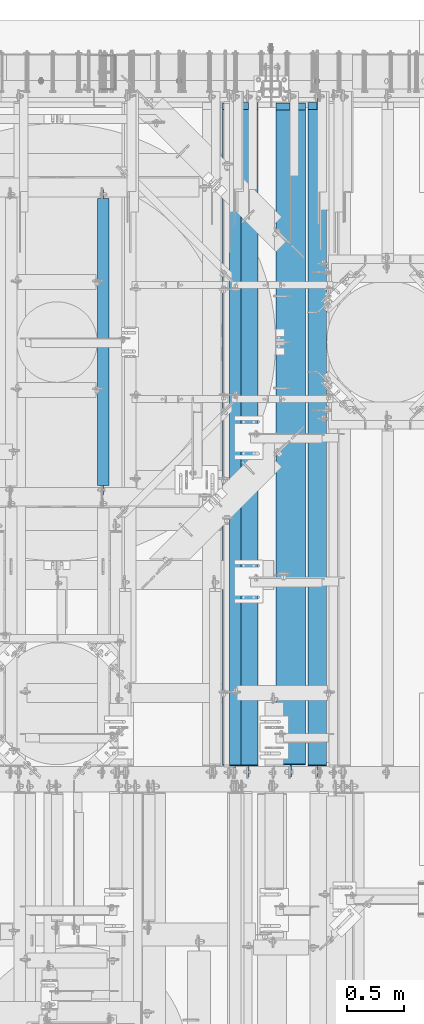
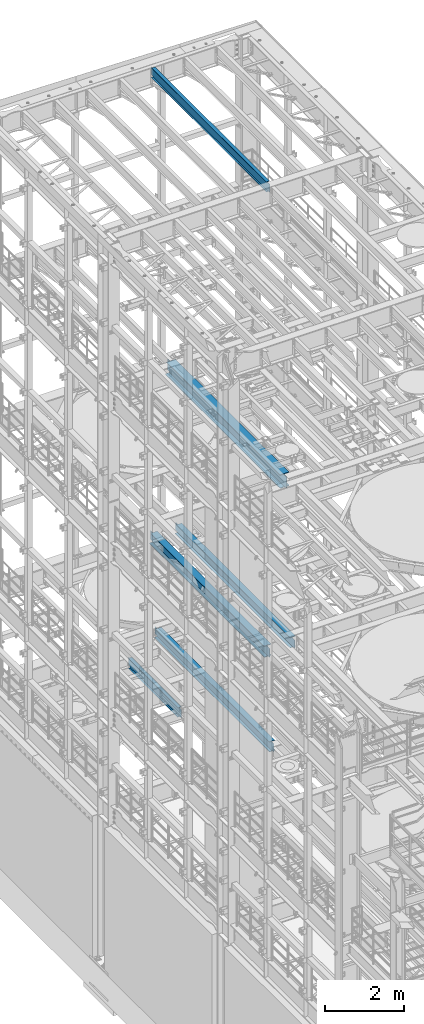
# One storey, part 1061 of 1876: 6 beams, 6 elements without a shape of their own.
"""IFC2X3 building model written with IfcOpenShell, lengths in millimetres."""

from ifc_helpers import new_model, si_unit, frame, origin_with_axes, place, context, subcontext, project, spatial, faceted_brep, material, type_object, element, aggregate, save


model = new_model("IFC2X3")

# Units and contexts
model_context = context("Model", 3, precision=1e-05, world=origin_with_axes())
body_context = subcontext(model_context, "Body", "Model", "MODEL_VIEW")
ifc_project = project(units=[si_unit("LENGTHUNIT", "METRE", prefix="MILLI"), si_unit("AREAUNIT", "SQUARE_METRE"), si_unit("VOLUMEUNIT", "CUBIC_METRE"), si_unit("MASSUNIT", "GRAM", prefix="KILO"), si_unit("TIMEUNIT", "SECOND"), si_unit("PLANEANGLEUNIT", "RADIAN"), si_unit("SOLIDANGLEUNIT", "STERADIAN"), si_unit("THERMODYNAMICTEMPERATUREUNIT", "DEGREE_CELSIUS"), si_unit("LUMINOUSINTENSITYUNIT", "LUMEN")], contexts=[model_context])

# Site, building, storey
site_placement = place(None, origin_with_axes())
site = spatial("IfcSite", under=ifc_project, at=site_placement, CompositionType="ELEMENT")
building_placement = place(site_placement, origin_with_axes())
building = spatial("IfcBuilding", under=site, at=building_placement, Name="Undefined", CompositionType="ELEMENT")
storey_placement = place(building_placement, origin_with_axes())
storey = spatial("IfcBuildingStorey", under=building, at=storey_placement, Name="Undefined", CompositionType="ELEMENT", Elevation=0.0)

# Assembly, beam
assembly_1_placement = place(storey_placement, origin_with_axes())
assembly_1 = element("IfcElementAssembly", 1, at=assembly_1_placement, inside=storey, Name="BEAM", AssemblyPlace="NOTDEFINED", PredefinedType="RIGID_FRAME")
ifc_material = material(Name="STEEL/A992")
beam_type_1 = type_object("IfcBeamType", Name="W12X26", PredefinedType="NOTDEFINED")
beam_1_placement = place(assembly_1_placement, frame((4879.975, 7620.0, 4975.225), z_axis=(0.0, 0.0, 1.0), x_axis=(0.0, 1.0, 0.0)))
beam_1 = element("IfcBeam", 2, at=beam_1_placement, type_object=beam_type_1, material=ifc_material, Name="BEAM", ObjectType="W12X26", context=body_context, shape_type="Brep", body=[
    faceted_brep([(19.8437512414296, -3.17500000000109, -130.175), (19.8437487585795, 3.17499999999927, -130.175), (102.393750190735, 3.17500000000018, -130.174999999999), (102.393750190735, -3.17500000000018, -130.174999999999), (107.25382970878, 3.17500000000018, -131.141729922587), (107.25382970878, -3.17500000000018, -131.141729922587), (111.374006176934, 3.17500000000018, -133.894743823064), (111.374006176934, -3.17500000000018, -133.894743823064), (114.127020077412, 3.17500000000018, -138.014920291218), (114.127020077412, -3.17500000000018, -138.014920291218), (115.09375, -3.17500000000018, -142.874999809264), (115.09375, 3.17500000000018, -142.874999809264), (115.09375, 3.17500000000018, -146.05), (115.09375, 82.5500000000002, -146.05), (115.09375, 82.5500000000002, -155.575000000001), (115.09375, -82.5500000000002, -155.575000000001), (115.09375, -82.5500000000002, -146.05), (115.09375, -3.17500000000018, -146.05), (5914.23125, 82.5500000000002, 146.05), (5914.23125, 3.17500000000018, 146.05), (127.79375, 3.17500000000018, 146.05), (127.793782276814, 82.5500000000102, 146.05), (115.09378246755, -3.17499999999654, 117.474999999999), (115.093782467549, 3.17500000000382, 117.474999999999), (19.8437487585795, 3.17499999999927, 117.474999999999), (19.8437512414296, -3.17500000000109, 117.474999999999), (119.953861985596, -3.17499999999654, 118.441729922587), (119.953861985596, 3.17500000000382, 118.441729922587), (124.074038453751, -3.17499999999654, 121.194743823065), (124.074038453751, 3.17500000000382, 121.194743823065), (126.82705235423, -3.17499999999654, 125.314920291219), (126.827052354229, 3.17500000000473, 125.314920291219), (127.793782276818, -3.17499999999654, 130.174999809265), (127.793782276817, 3.17500000000382, 130.174999809265), (5914.23125, -82.5500000000002, 155.575), (5914.23125, 82.5500000000002, 155.575), (127.793782276814, 82.5500000000102, 155.575), (127.793782276821, -82.5500000000029, 155.575), (5914.23125, -82.5500000000002, 146.05), (127.793782276821, -82.5500000000029, 146.05), (5914.23125, -3.17500000000018, 146.05), (127.79375, -3.17500000000018, 146.05), (5914.23125, -3.17500000000018, 117.474999809267), (5914.23125, 3.17500000000018, 117.474999809267), (5915.19797992259, -3.17500000000018, 112.614920291221), (5915.19797992259, 3.17500000000018, 112.614920291221), (5917.95099382307, -3.17500000000018, 108.494743823067), (5917.95099382307, 3.17500000000018, 108.494743823067), (5922.07117029122, -3.17500000000018, 105.741729922589), (5922.07117029122, 3.17500000000018, 105.741729922589), (5926.93124980926, -3.17500000000018, 104.775000000001), (5926.93124980926, 3.17500000000018, 104.775000000001), (6072.98125, -3.17500000000018, 104.775000000001), (6072.98125, 3.17500000000018, 104.775000000001), (6072.98125, -3.17500000000018, -130.174999999999), (6072.98125, 3.17500000000018, -130.174999999999), (5990.43124980926, -3.17500000000018, -130.174999999999), (5990.43124980926, 3.17500000000018, -130.174999999999), (5985.57117029122, -3.17500000000018, -131.141729922587), (5985.57117029122, 3.17500000000018, -131.141729922587), (5981.45099382307, -3.17500000000018, -133.894743823065), (5981.45099382307, 3.17500000000018, -133.894743823065), (5978.69797992259, -3.17500000000018, -138.014920291219), (5978.69797992259, 3.17500000000018, -138.014920291219), (5977.73125, -3.17500000000018, -142.874999809264), (5977.73125, 3.17500000000018, -142.874999809264), (5977.73125, -3.17500000000018, -146.05), (5977.73125, -82.5500000000002, -146.05), (5977.73125, -82.5500000000002, -155.575), (5977.73125, 82.5500000000002, -155.575), (5977.73125, 82.5500000000002, -146.05), (5977.73125, 3.17500000000018, -146.05)], [[[0, 1, 2, 3]], [[3, 2, 4, 5]], [[5, 4, 6, 7]], [[7, 6, 8, 9]], [[10, 11, 12, 13, 14, 15, 16, 17]], [[9, 8, 11, 10]], [[18, 19, 20, 21]], [[22, 23, 24, 25]], [[26, 27, 23, 22]], [[28, 29, 27, 26]], [[30, 31, 29, 28]], [[32, 33, 31, 30]], [[34, 35, 36, 37]], [[38, 34, 37, 39]], [[40, 38, 39, 41]], [[37, 36, 21, 20, 33, 32, 41, 39]], [[35, 18, 21, 36]], [[34, 38, 40, 42, 43, 19, 18, 35]], [[44, 45, 43, 42]], [[46, 47, 45, 44]], [[48, 49, 47, 46]], [[50, 51, 49, 48]], [[52, 53, 51, 50]], [[53, 52, 54, 55]], [[54, 56, 57, 55]], [[58, 59, 57, 56]], [[60, 61, 59, 58]], [[62, 63, 61, 60]], [[64, 65, 63, 62]], [[66, 67, 68, 69, 70, 71, 65, 64]], [[67, 66, 17, 16]], [[68, 67, 16, 15]], [[69, 68, 15, 14]], [[70, 69, 14, 13]], [[71, 70, 13, 12]], [[6, 4, 2, 1, 24, 23, 27, 29, 31, 33, 20, 19, 43, 45, 47, 49, 51, 53, 55, 57, 59, 61, 63, 65, 71, 12, 11, 8]], [[25, 24, 1, 0]], [[66, 64, 62, 60, 58, 56, 54, 52, 50, 48, 46, 44, 42, 40, 41, 32, 30, 28, 26, 22, 25, 0, 3, 5, 7, 9, 10, 17]]]),
])
aggregate(assembly_1, [beam_1])

assembly_2_placement = place(storey_placement, origin_with_axes())
assembly_2 = element("IfcElementAssembly", 3, at=assembly_2_placement, inside=storey, Name="BEAM", AssemblyPlace="NOTDEFINED", PredefinedType="RIGID_FRAME")
beam_type_2 = type_object("IfcBeamType", Name="W12X16", PredefinedType="NOTDEFINED")
beam_2_placement = place(assembly_2_placement, frame((3594.1, 10115.55, 4978.4), z_axis=(0.0, 0.0, 1.0), x_axis=(0.0, 1.0, 0.0)))
beam_2 = element("IfcBeam", 4, at=beam_2_placement, type_object=beam_type_2, material=ifc_material, Name="BEAM", ObjectType="W12X16", context=body_context, shape_type="Brep", body=[
    faceted_brep([(15.8749999999982, -3.17500000000018, -127.0), (15.8749999999982, 3.17500000000018, -127.0), (98.425000190733, 3.17500000000018, -127.0), (98.425000190733, -3.17500000000018, -127.0), (103.285079708779, 3.17500000000018, -127.966729922588), (103.285079708779, -3.17500000000018, -127.966729922588), (107.405256176932, 3.17500000000018, -130.719743823065), (107.405256176932, -3.17500000000018, -130.719743823065), (110.158270077411, 3.17500000000018, -134.839920291219), (110.158270077411, -3.17500000000018, -134.839920291219), (111.124999999998, -3.17500000000018, -139.699999809265), (111.124999999998, 3.17500000000018, -139.699999809265), (111.124999999998, 3.17500000000018, -146.049999999999), (111.124999999998, 50.8000000000002, -146.049999999999), (111.124999999998, 50.8000000000002, -152.400000000001), (111.124999999998, -50.8000000000002, -152.400000000001), (111.124999999998, -50.8000000000002, -146.049999999999), (111.124999999998, -3.17500000000018, -146.049999999999), (2632.07499999958, 50.8000000000002, 146.05), (2632.07499999958, 3.17500000000018, 146.05), (98.4250000000029, 3.17500000000018, 146.049999999999), (98.4250000000029, 50.8000000000002, 146.049999999999), (85.7250001907378, -3.17500000000018, 127.000000000001), (85.7250001907378, 3.17500000000018, 127.000000000001), (15.875, 3.17500000000018, 127.000000000001), (15.875, -3.17500000000018, 127.000000000001), (90.5850797087842, -3.17500000000018, 127.966729922588), (90.5850797087842, 3.17500000000018, 127.966729922588), (94.7052561769378, -3.17500000000018, 130.719743823067), (94.7052561769378, 3.17500000000018, 130.719743823067), (97.4582700774154, -3.17500000000018, 134.839920291221), (97.4582700774154, 3.17500000000018, 134.839920291221), (98.4250000000029, -3.17500000000018, 139.699999809266), (98.4250000000029, 3.17500000000018, 139.699999809266), (2632.07499999958, -50.8000000000002, 152.4), (2632.07499999958, 50.8000000000002, 152.4), (98.4250000000029, 50.8000000000002, 152.4), (98.4250000000029, -50.8000000000002, 152.4), (2632.07499999958, -50.8000000000002, 146.05), (98.4250000000029, -50.8000000000002, 146.049999999999), (2632.07499999958, -3.17500000000018, 146.05), (98.4250000000029, -3.17500000000018, 146.049999999999), (2632.07499999958, -3.17500000000018, 139.699999809266), (2632.07499999958, 3.17500000000018, 139.699999809266), (2633.04172992217, -3.17500000000018, 134.839920291221), (2633.04172992217, 3.17500000000018, 134.839920291221), (2635.79474382265, -3.17500000000018, 130.719743823067), (2635.79474382265, 3.17500000000018, 130.719743823067), (2639.9149202908, -3.17500000000018, 127.966729922588), (2639.9149202908, 3.17500000000018, 127.966729922588), (2644.77499980885, -3.17500000000018, 127.000000000001), (2644.77499980885, 3.17500000000018, 127.000000000001), (2714.62499999958, -3.17500000000018, 127.000000000001), (2714.62499999958, 3.17500000000018, 127.000000000001), (2714.62499999958, -3.17500000000018, -126.999999999999), (2714.62499999958, 3.17500000000018, -126.999999999999), (2632.07499980885, -3.17500000000018, -126.999999999999), (2632.07499980885, 3.17500000000018, -126.999999999999), (2627.2149202908, -3.17500000000018, -127.966729922587), (2627.2149202908, 3.17500000000018, -127.966729922587), (2623.09474382265, -3.17500000000018, -130.719743823065), (2623.09474382265, 3.17500000000018, -130.719743823065), (2620.34172992217, -3.17500000000018, -134.839920291219), (2620.34172992217, 3.17500000000018, -134.839920291219), (2619.37499999958, -3.17500000000018, -139.699999809264), (2619.37499999958, 3.17500000000018, -139.699999809264), (2619.37499999958, -3.17500000000018, -146.05), (2619.37499999958, -50.8000000000002, -146.05), (2619.37499999958, -50.8000000000002, -152.4), (2619.37499999958, 50.8000000000002, -152.4), (2619.37499999958, 50.8000000000002, -146.05), (2619.37499999958, 3.17500000000018, -146.05)], [[[0, 1, 2, 3]], [[3, 2, 4, 5]], [[5, 4, 6, 7]], [[7, 6, 8, 9]], [[10, 11, 12, 13, 14, 15, 16, 17]], [[9, 8, 11, 10]], [[18, 19, 20, 21]], [[22, 23, 24, 25]], [[26, 27, 23, 22]], [[28, 29, 27, 26]], [[30, 31, 29, 28]], [[32, 33, 31, 30]], [[34, 35, 36, 37]], [[38, 34, 37, 39]], [[40, 38, 39, 41]], [[37, 36, 21, 20, 33, 32, 41, 39]], [[35, 18, 21, 36]], [[34, 38, 40, 42, 43, 19, 18, 35]], [[44, 45, 43, 42]], [[46, 47, 45, 44]], [[48, 49, 47, 46]], [[50, 51, 49, 48]], [[52, 53, 51, 50]], [[53, 52, 54, 55]], [[54, 56, 57, 55]], [[58, 59, 57, 56]], [[60, 61, 59, 58]], [[62, 63, 61, 60]], [[64, 65, 63, 62]], [[66, 67, 68, 69, 70, 71, 65, 64]], [[67, 66, 17, 16]], [[68, 67, 16, 15]], [[69, 68, 15, 14]], [[70, 69, 14, 13]], [[71, 70, 13, 12]], [[6, 4, 2, 1, 24, 23, 27, 29, 31, 33, 20, 19, 43, 45, 47, 49, 51, 53, 55, 57, 59, 61, 63, 65, 71, 12, 11, 8]], [[25, 24, 1, 0]], [[66, 64, 62, 60, 58, 56, 54, 52, 50, 48, 46, 44, 42, 40, 41, 32, 30, 28, 26, 22, 25, 0, 3, 5, 7, 9, 10, 17]]]),
])
aggregate(assembly_2, [beam_2])

assembly_3_placement = place(storey_placement, origin_with_axes())
assembly_3 = element("IfcElementAssembly", 5, at=assembly_3_placement, inside=storey, Name="BEAM", AssemblyPlace="NOTDEFINED", PredefinedType="RIGID_FRAME")
beam_3_placement = place(assembly_3_placement, frame((4762.5, 7620.0, 22402.8), z_axis=(0.0, 0.0, 1.0), x_axis=(0.0, 1.0, 0.0)))
beam_3 = element("IfcBeam", 6, at=beam_3_placement, type_object=beam_type_2, material=ifc_material, Name="BEAM", ObjectType="W12X16", context=body_context, shape_type="Brep", body=[
    faceted_brep([(19.84375, -3.17499999999995, -126.999999999996), (19.84375, 3.17499999999995, -126.999999999996), (102.393750190735, 3.17500000000018, -127.000000000001), (102.393750190735, -3.17500000000018, -127.000000000001), (107.25382970878, 3.17500000000018, -127.966729922588), (107.25382970878, -3.17500000000018, -127.966729922588), (111.374006176934, 3.17500000000018, -130.719743823067), (111.374006176934, -3.17500000000018, -130.719743823067), (114.127020077412, 3.17500000000018, -134.839920291221), (114.127020077412, -3.17500000000018, -134.839920291221), (115.09375, -3.17500000000018, -139.699999809266), (115.09375, 3.17500000000018, -139.699999809266), (115.09375, 3.17500000000018, -146.05), (115.09375, 50.8000000000002, -146.05), (115.09375, 50.8000000000002, -152.4), (115.09375, -50.8000000000002, -152.4), (115.09375, -50.8000000000002, -146.05), (115.09375, -3.17500000000018, -146.05), (127.79375, 3.17500000000018, 146.05), (127.79375, 50.8000000000002, 146.05), (5968.20625, 50.8, 146.05), (5968.20625, 3.17499999999995, 146.05), (115.093750190735, -3.17500000000018, 114.299999999999), (115.093750190735, 3.17500000000018, 114.299999999999), (19.84375, 3.17500000000018, 114.299999999999), (19.84375, -3.17500000000018, 114.299999999999), (119.95382970878, -3.17500000000018, 115.266729922587), (119.95382970878, 3.17500000000018, 115.266729922587), (124.074006176934, -3.17500000000018, 118.019743823065), (124.074006176934, 3.17500000000018, 118.019743823065), (126.827020077412, -3.17500000000018, 122.139920291219), (126.827020077412, 3.17500000000018, 122.139920291219), (127.79375, -3.17500000000018, 126.999999809264), (127.79375, 3.17500000000018, 126.999999809264), (127.79375, 50.8000000000002, 152.4), (127.79375, -50.8000000000002, 152.4), (5968.20625, -50.8, 152.4), (5968.20625, 50.8, 152.4), (127.79375, -50.8000000000002, 146.05), (5968.20625, -50.8, 146.05), (127.79375, -3.17500000000018, 146.05), (5968.20625, -3.17499999999995, 146.05), (5968.20625, -3.17499999999995, 126.999999809264), (5968.20625, 3.17499999999995, 126.999999809264), (5969.17297992259, -3.17499999999995, 122.139920291219), (5969.17297992259, 3.17499999999995, 122.139920291219), (5971.92599382307, -3.17499999999995, 118.019743823065), (5971.92599382307, 3.17499999999995, 118.019743823065), (5976.04617029122, -3.17499999999995, 115.266729922587), (5976.04617029122, 3.17499999999995, 115.266729922587), (5980.90624980927, -3.17499999999995, 114.299999999999), (5980.90624980927, 3.17499999999995, 114.299999999999), (6076.15625, -3.17499999999995, 114.299999999999), (6076.15625, 3.17499999999995, 114.299999999999), (6076.15625, -3.17499999999995, -126.999999999996), (6076.15625, 3.17499999999995, -126.999999999996), (5993.60624980927, -3.17499999999995, -127.000000000001), (5993.60624980927, 3.17499999999995, -127.000000000001), (5988.74617029122, -3.17499999999995, -127.966729922588), (5988.74617029122, 3.17499999999995, -127.966729922588), (5984.62599382307, -3.17499999999995, -130.719743823067), (5984.62599382307, 3.17499999999995, -130.719743823067), (5981.87297992259, -3.17499999999995, -134.839920291221), (5981.87297992259, 3.17499999999995, -134.839920291221), (5980.90625, -3.17499999999995, -139.699999809266), (5980.90625, 3.17499999999995, -139.699999809266), (5980.90625, -3.17499999999995, -146.05), (5980.90625, -50.8, -146.05), (5980.90625, -50.8, -152.4), (5980.90625, 50.8, -152.4), (5980.90625, 50.8, -146.05), (5980.90625, 3.17499999999995, -146.05)], [[[0, 1, 2, 3]], [[3, 2, 4, 5]], [[5, 4, 6, 7]], [[7, 6, 8, 9]], [[10, 11, 12, 13, 14, 15, 16, 17]], [[9, 8, 11, 10]], [[18, 19, 20, 21]], [[22, 23, 24, 25]], [[26, 27, 23, 22]], [[28, 29, 27, 26]], [[30, 31, 29, 28]], [[32, 33, 31, 30]], [[34, 35, 36, 37]], [[35, 38, 39, 36]], [[38, 40, 41, 39]], [[35, 34, 19, 18, 33, 32, 40, 38]], [[19, 34, 37, 20]], [[36, 39, 41, 42, 43, 21, 20, 37]], [[44, 45, 43, 42]], [[46, 47, 45, 44]], [[48, 49, 47, 46]], [[50, 51, 49, 48]], [[52, 53, 51, 50]], [[53, 52, 54, 55]], [[54, 56, 57, 55]], [[58, 59, 57, 56]], [[60, 61, 59, 58]], [[62, 63, 61, 60]], [[64, 65, 63, 62]], [[66, 67, 68, 69, 70, 71, 65, 64]], [[17, 16, 67, 66]], [[16, 15, 68, 67]], [[15, 14, 69, 68]], [[14, 13, 70, 69]], [[13, 12, 71, 70]], [[59, 61, 63, 65, 71, 12, 11, 8, 6, 4, 2, 1, 24, 23, 27, 29, 31, 33, 18, 21, 43, 45, 47, 49, 51, 53, 55, 57]], [[25, 24, 1, 0]], [[52, 50, 48, 46, 44, 42, 41, 40, 32, 30, 28, 26, 22, 25, 0, 3, 5, 7, 9, 10, 17, 66, 64, 62, 60, 58, 56, 54]]]),
])
aggregate(assembly_3, [beam_3])

assembly_4_placement = place(storey_placement, origin_with_axes())
assembly_4 = element("IfcElementAssembly", 7, at=assembly_4_placement, inside=storey, Name="BEAM", AssemblyPlace="NOTDEFINED", PredefinedType="RIGID_FRAME")
beam_type_3 = type_object("IfcBeamType", Name="W12X30", PredefinedType="NOTDEFINED")
beam_4_placement = place(assembly_4_placement, frame((5486.4, 7620.0, 7996.2375), z_axis=(0.0, 0.0, 1.0), x_axis=(0.0, 1.0, 0.0)))
beam_4 = element("IfcBeam", 8, at=beam_4_placement, type_object=beam_type_3, material=ifc_material, Name="BEAM", ObjectType="W12X30", context=body_context, shape_type="Brep", body=[
    faceted_brep([(19.8437500000002, -3.17500000000018, -131.762499999993), (19.8437500000002, 3.17500000000018, -131.762499999993), (102.393750190735, 3.17500000000018, -131.762500000001), (102.393750190735, -3.17500000000018, -131.762500000001), (107.25382970878, 3.17500000000018, -132.729229922588), (107.25382970878, -3.17500000000018, -132.729229922588), (111.374006176934, 3.17500000000018, -135.482243823067), (111.374006176934, -3.17500000000018, -135.482243823067), (114.127020077412, 3.17500000000018, -139.60242029122), (114.127020077412, -3.17500000000018, -139.60242029122), (115.09375, -3.17500000000018, -144.462499809266), (115.09375, 3.17500000000018, -144.462499809266), (115.09375, 3.17500000000018, -146.05), (115.09375, 82.5500000000002, -146.05), (115.09375, 82.5500000000002, -157.1625), (115.09375, -82.5500000000002, -157.1625), (115.09375, -82.5500000000002, -146.05), (115.09375, -3.17500000000018, -146.05), (5914.23125, 82.5500000000002, 146.05), (5914.23125, 3.17500000000018, 146.05), (127.79375, 3.17500000000018, 146.05), (127.793782276814, 82.5500000000102, 146.05), (115.09374930124, -3.17499999999995, 119.062500000004), (115.09374930124, 3.17499999999995, 119.062500000004), (19.8437491105051, 3.17499999999995, 119.062500000004), (19.8437491105051, -3.17499999999995, 119.062500000004), (119.953828819285, -3.17499999999995, 120.029229922591), (119.953828819285, 3.17499999999995, 120.029229922591), (124.074005287439, -3.17499999999995, 122.782243823069), (124.074005287439, 3.17499999999995, 122.782243823069), (126.827019187917, -3.17499999999995, 126.902420291222), (126.827019187917, 3.17499999999995, 126.902420291222), (127.793749110505, -3.17499999999995, 131.762499809269), (127.793749110505, 3.17499999999995, 131.762499809269), (5914.23125, -82.5500000000002, 157.1625), (5914.23125, 82.5500000000002, 157.1625), (127.793749110505, 82.55, 157.162499999999), (127.793749110505, -82.55, 157.162499999999), (5914.23125, -82.5500000000002, 146.05), (127.793782276821, -82.5500000000029, 146.05), (5914.23125, -3.17500000000018, 146.05), (127.79375, -3.17500000000018, 146.05), (5914.23125, -3.17500000000018, 119.062499809265), (5914.23125, 3.17500000000018, 119.062499809265), (5915.19797992259, -3.17500000000018, 114.20242029122), (5915.19797992259, 3.17500000000018, 114.20242029122), (5917.95099382307, -3.17500000000018, 110.082243823066), (5917.95099382307, 3.17500000000018, 110.082243823066), (5922.07117029122, -3.17500000000018, 107.329229922588), (5922.07117029122, 3.17500000000018, 107.329229922588), (5926.93124980926, -3.17500000000018, 106.3625), (5926.93124980926, 3.17500000000018, 106.3625), (6072.98125, -3.17500000000018, 106.3625), (6072.98125, 3.17500000000018, 106.3625), (6072.98125, -3.17500000000018, -131.7625), (6072.98125, 3.17500000000018, -131.7625), (5990.43124980926, -3.17500000000018, -131.7625), (5990.43124980926, 3.17500000000018, -131.7625), (5985.57117029122, -3.17500000000018, -132.729229922587), (5985.57117029122, 3.17500000000018, -132.729229922587), (5981.45099382307, -3.17500000000018, -135.482243823066), (5981.45099382307, 3.17500000000018, -135.482243823066), (5978.69797992259, -3.17500000000018, -139.602420291219), (5978.69797992259, 3.17500000000018, -139.602420291219), (5977.73125, -3.17500000000018, -144.462499809265), (5977.73125, 3.17500000000018, -144.462499809265), (5977.73125, -3.17500000000018, -146.05), (5977.73125, -82.5500000000002, -146.05), (5977.73125, -82.5500000000002, -157.1625), (5977.73125, 82.5500000000002, -157.1625), (5977.73125, 82.5500000000002, -146.05), (5977.73125, 3.17500000000018, -146.05)], [[[0, 1, 2, 3]], [[3, 2, 4, 5]], [[5, 4, 6, 7]], [[7, 6, 8, 9]], [[10, 11, 12, 13, 14, 15, 16, 17]], [[9, 8, 11, 10]], [[18, 19, 20, 21]], [[22, 23, 24, 25]], [[26, 27, 23, 22]], [[28, 29, 27, 26]], [[30, 31, 29, 28]], [[32, 33, 31, 30]], [[34, 35, 36, 37]], [[38, 34, 37, 39]], [[40, 38, 39, 41]], [[37, 36, 21, 20, 33, 32, 41, 39]], [[35, 18, 21, 36]], [[34, 38, 40, 42, 43, 19, 18, 35]], [[44, 45, 43, 42]], [[46, 47, 45, 44]], [[48, 49, 47, 46]], [[50, 51, 49, 48]], [[52, 53, 51, 50]], [[53, 52, 54, 55]], [[54, 56, 57, 55]], [[58, 59, 57, 56]], [[60, 61, 59, 58]], [[62, 63, 61, 60]], [[64, 65, 63, 62]], [[66, 67, 68, 69, 70, 71, 65, 64]], [[67, 66, 17, 16]], [[68, 67, 16, 15]], [[69, 68, 15, 14]], [[70, 69, 14, 13]], [[71, 70, 13, 12]], [[6, 4, 2, 1, 24, 23, 27, 29, 31, 33, 20, 19, 43, 45, 47, 49, 51, 53, 55, 57, 59, 61, 63, 65, 71, 12, 11, 8]], [[25, 24, 1, 0]], [[66, 64, 62, 60, 58, 56, 54, 52, 50, 48, 46, 44, 42, 40, 41, 32, 30, 28, 26, 22, 25, 0, 3, 5, 7, 9, 10, 17]]]),
])
aggregate(assembly_4, [beam_4])

assembly_5_placement = place(storey_placement, origin_with_axes())
assembly_5 = element("IfcElementAssembly", 9, at=assembly_5_placement, inside=storey, Name="BEAM", AssemblyPlace="NOTDEFINED", PredefinedType="RIGID_FRAME")
beam_type_4 = type_object("IfcBeamType", Name="W14X48", PredefinedType="NOTDEFINED")
beam_5_placement = place(assembly_5_placement, frame((4749.8, 7620.0, 7978.775), z_axis=(0.0, 0.0, 1.0), x_axis=(0.0, 1.0, 0.0)))
beam_5 = element("IfcBeam", 10, at=beam_5_placement, type_object=beam_type_4, material=ifc_material, Name="BEAM", ObjectType="W14X48", context=body_context, shape_type="Brep", body=[
    faceted_brep([(19.84375, -3.96875, -142.875000000001), (19.84375, 3.96875, -142.875000000001), (108.743750190735, 3.96875, -142.875000000001), (108.743750190735, -3.96875, -142.875000000001), (113.603829708781, 3.96875, -143.841729922588), (113.603829708781, -3.96875, -143.841729922588), (117.724006176934, 3.96875, -146.594743823067), (117.724006176934, -3.96875, -146.594743823067), (120.477020077413, 3.96875, -150.714920291221), (120.477020077413, -3.96875, -150.714920291221), (121.44375, -3.96875, -155.574999809266), (121.44375, 3.96875, -155.574999809266), (121.44375, 3.96875, -158.75), (121.44375, 101.6, -158.75), (121.443749999999, 101.6, -174.625), (121.443749999999, -101.6, -174.625), (121.44375, -101.6, -158.75), (121.44375, -3.96875, -158.75), (5914.23125, 101.6, 158.75), (5914.23125, 3.96875, 158.75), (127.79375, 3.96875, 158.75), (127.79375, 101.6, 158.75), (115.093750190735, -3.96875, 136.524999999999), (115.093750190735, 3.96875, 136.524999999999), (19.8437500000002, 3.96875, 136.524999999999), (19.8437500000002, -3.96875, 136.524999999999), (119.95382970878, -3.96875, 137.491729922586), (119.95382970878, 3.96875, 137.491729922586), (124.074006176934, -3.96875, 140.244743823065), (124.074006176934, 3.96875, 140.244743823065), (126.827020077412, -3.96875, 144.364920291218), (126.827020077412, 3.96875, 144.364920291218), (127.79375, -3.96875, 149.224999809264), (127.79375, 3.96875, 149.224999809264), (5914.23125, -101.6, 174.625), (5914.23125, 101.6, 174.625), (127.79375, 101.6, 174.625), (127.79375, -101.6, 174.625), (5914.23125, -101.6, 158.75), (127.79375, -101.6, 158.75), (5914.23125, -3.96875, 158.75), (127.79375, -3.96875, 158.75), (5914.23125, -3.96875, 136.524999809265), (5914.23125, 3.96875, 136.524999809265), (5915.19797992259, -3.96875, 131.664920291219), (5915.19797992259, 3.96875, 131.664920291219), (5917.95099382307, -3.96875, 127.544743823066), (5917.95099382307, 3.96875, 127.544743823066), (5922.07117029122, -3.96875, 124.791729922587), (5922.07117029122, 3.96875, 124.791729922587), (5926.93124980926, -3.96875, 123.825), (5926.93124980926, 3.96875, 123.825), (6072.98125, -3.96875, 123.825), (6072.98125, 3.96875, 123.825), (6072.98125, -3.96875, -142.875), (6072.98125, 3.96875, -142.875), (5984.08124980926, -3.96875, -142.875), (5984.08124980926, 3.96875, -142.875), (5979.22117029122, -3.96875, -143.841729922588), (5979.22117029122, 3.96875, -143.841729922588), (5975.10099382306, -3.96875, -146.594743823066), (5975.10099382306, 3.96875, -146.594743823066), (5972.34797992259, -3.96875, -150.71492029122), (5972.34797992259, 3.96875, -150.71492029122), (5971.38125, -3.96875, -155.574999809265), (5971.38125, 3.96875, -155.574999809265), (5971.38125, -3.96875, -158.75), (5971.38125, -101.6, -158.75), (5971.38125, -101.6, -174.625), (5971.38125, 101.6, -174.625), (5971.38125, 101.6, -158.75), (5971.38125, 3.96875, -158.75)], [[[0, 1, 2, 3]], [[3, 2, 4, 5]], [[5, 4, 6, 7]], [[7, 6, 8, 9]], [[10, 11, 12, 13, 14, 15, 16, 17]], [[9, 8, 11, 10]], [[18, 19, 20, 21]], [[22, 23, 24, 25]], [[26, 27, 23, 22]], [[28, 29, 27, 26]], [[30, 31, 29, 28]], [[32, 33, 31, 30]], [[34, 35, 36, 37]], [[38, 34, 37, 39]], [[40, 38, 39, 41]], [[37, 36, 21, 20, 33, 32, 41, 39]], [[35, 18, 21, 36]], [[34, 38, 40, 42, 43, 19, 18, 35]], [[44, 45, 43, 42]], [[46, 47, 45, 44]], [[48, 49, 47, 46]], [[50, 51, 49, 48]], [[52, 53, 51, 50]], [[53, 52, 54, 55]], [[54, 56, 57, 55]], [[58, 59, 57, 56]], [[60, 61, 59, 58]], [[62, 63, 61, 60]], [[64, 65, 63, 62]], [[66, 67, 68, 69, 70, 71, 65, 64]], [[67, 66, 17, 16]], [[68, 67, 16, 15]], [[69, 68, 15, 14]], [[70, 69, 14, 13]], [[71, 70, 13, 12]], [[6, 4, 2, 1, 24, 23, 27, 29, 31, 33, 20, 19, 43, 45, 47, 49, 51, 53, 55, 57, 59, 61, 63, 65, 71, 12, 11, 8]], [[25, 24, 1, 0]], [[66, 64, 62, 60, 58, 56, 54, 52, 50, 48, 46, 44, 42, 40, 41, 32, 30, 28, 26, 22, 25, 0, 3, 5, 7, 9, 10, 17]]]),
])
aggregate(assembly_5, [beam_5])

assembly_6_placement = place(storey_placement, origin_with_axes())
assembly_6 = element("IfcElementAssembly", 11, at=assembly_6_placement, inside=storey, Name="BEAM", AssemblyPlace="NOTDEFINED", PredefinedType="RIGID_FRAME")
beam_type_5 = type_object("IfcBeamType", Name="W16X89", PredefinedType="NOTDEFINED")
beam_6_placement = place(assembly_6_placement, frame((5251.44999844433, 7619.99818280265, 13096.875), z_axis=(0.0, 0.0, 1.0), x_axis=(0.0, 1.0, 0.0)))
beam_6 = element("IfcBeam", 12, at=beam_6_placement, type_object=beam_type_5, material=ifc_material, Name="BEAM", ObjectType="W16X89", context=body_context, shape_type="Brep", body=[
    faceted_brep([(5973.76431719735, -6.35000000000036, -190.5), (5973.76431719735, -131.7625, -190.5), (5973.76431719735, -131.7625, -212.725), (5973.76431719735, 131.7625, -212.725), (5973.76431719735, 131.7625, -190.5), (5973.76431719735, 6.35000000000036, -190.5), (5973.76431719735, 6.35000000000036, -187.324999809263), (5973.76431719735, -6.35000000000036, -187.324999809263), (5974.73104711993, 6.35000000000036, -182.464920291217), (5974.73104711993, -6.35000000000036, -182.464920291217), (5977.48406102041, 6.35000000000036, -178.344743823063), (5977.48406102041, -6.35000000000036, -178.344743823063), (5981.60423748857, 6.35000000000036, -175.591729922586), (5981.60423748857, -6.35000000000036, -175.591729922586), (5986.46431700661, 6.35000000000036, -174.624999999998), (5986.46431700661, -6.35000000000036, -174.624999999998), (6075.36431719735, -6.35000000000036, -174.624999999998), (6075.36431719735, 6.35000000000036, -174.624999999998), (134.14556719735, 6.35000000000036, 190.5), (134.14556719735, 131.7625, 190.5), (5910.26431719735, 131.7625, 190.5), (5910.26431719735, 6.35000000000036, 190.5), (127.79556719735, -6.35000000000036, -187.324999809265), (127.79556719735, 6.35000000000036, -187.324999809265), (127.79556719735, 6.35000000000036, -190.5), (127.79556719735, 131.7625, -190.5), (127.79556719735, 131.7625, -212.725), (127.79556719735, -131.7625, -212.725), (127.79556719735, -131.7625, -190.5), (127.79556719735, -6.35000000000036, -190.5), (126.828837274762, -6.35000000000036, -182.464920291219), (126.828837274762, 6.35000000000036, -182.464920291219), (124.075823374284, -6.35000000000036, -178.344743823065), (124.075823374284, 6.35000000000036, -178.344743823065), (119.95564690613, -6.35000000000036, -175.591729922588), (119.95564690613, 6.35000000000036, -175.591729922588), (115.095567388084, -6.35000000000036, -174.625), (115.095567388084, 6.35000000000036, -174.625), (19.8455671973497, -6.35000000000036, -174.625), (19.8455671973497, 6.35000000000036, -174.625), (19.8455671973497, -6.35000000000036, 168.275), (19.8455671973497, 6.35000000000036, 168.275), (121.445567388085, -6.35000000000036, 168.275), (121.445567388085, 6.35000000000036, 168.275), (126.30564690613, -6.35000000000036, 169.241729922587), (126.30564690613, 6.35000000000036, 169.241729922587), (130.425823374284, -6.35000000000036, 171.994743823065), (130.425823374284, 6.35000000000036, 171.994743823065), (133.178837274762, -6.35000000000036, 176.114920291218), (133.178837274762, 6.35000000000036, 176.114920291218), (134.14556719735, -6.35000000000036, 180.974999809265), (134.14556719735, 6.35000000000036, 180.974999809265), (134.14556719735, -131.7625, 212.725), (134.14556719735, 131.7625, 212.725), (134.14556719735, -6.35000000000036, 190.5), (134.14556719735, -131.7625, 190.5), (5910.26431719735, -6.35000000000036, 190.5), (5910.26431719735, -131.7625, 190.5), (5910.26431719735, -131.7625, 212.725), (5910.26431719735, 131.7625, 212.725), (5910.26431719735, -6.35000000000036, 180.974999809267), (5910.26431719735, 6.35000000000036, 180.974999809267), (5911.23104711993, -6.35000000000036, 176.11492029122), (5911.23104711993, 6.35000000000036, 176.11492029122), (5913.98406102041, -6.35000000000036, 171.994743823067), (5913.98406102041, 6.35000000000036, 171.994743823067), (5918.10423748857, -6.35000000000036, 169.241729922589), (5918.10423748857, 6.35000000000036, 169.241729922589), (5922.96431700661, -6.35000000000036, 168.275000000001), (5922.96431700661, 6.35000000000036, 168.275000000001), (6075.36431719735, -6.35000000000036, 168.275000000001), (6075.36431719735, 6.35000000000036, 168.275000000001)], [[[0, 1, 2, 3, 4, 5, 6, 7]], [[7, 6, 8, 9]], [[9, 8, 10, 11]], [[11, 10, 12, 13]], [[13, 12, 14, 15]], [[16, 15, 14, 17]], [[18, 19, 20, 21]], [[22, 23, 24, 25, 26, 27, 28, 29]], [[30, 31, 23, 22]], [[32, 33, 31, 30]], [[34, 35, 33, 32]], [[36, 37, 35, 34]], [[38, 39, 37, 36]], [[40, 41, 39, 38]], [[42, 43, 41, 40]], [[44, 45, 43, 42]], [[46, 47, 45, 44]], [[48, 49, 47, 46]], [[50, 51, 49, 48]], [[52, 53, 19, 18, 51, 50, 54, 55]], [[55, 54, 56, 57]], [[52, 55, 57, 58]], [[53, 52, 58, 59]], [[19, 53, 59, 20]], [[58, 57, 56, 60, 61, 21, 20, 59]], [[62, 63, 61, 60]], [[64, 65, 63, 62]], [[66, 67, 65, 64]], [[68, 69, 67, 66]], [[70, 71, 69, 68]], [[71, 70, 16, 17]], [[12, 10, 8, 6, 5, 24, 23, 31, 33, 35, 37, 39, 41, 43, 45, 47, 49, 51, 18, 21, 61, 63, 65, 67, 69, 71, 17, 14]], [[25, 24, 5, 4]], [[26, 25, 4, 3]], [[27, 26, 3, 2]], [[28, 27, 2, 1]], [[29, 28, 1, 0]], [[70, 68, 66, 64, 62, 60, 56, 54, 50, 48, 46, 44, 42, 40, 38, 36, 34, 32, 30, 22, 29, 0, 7, 9, 11, 13, 15, 16]]]),
])
aggregate(assembly_6, [beam_6])

save(model, "model.ifc")
